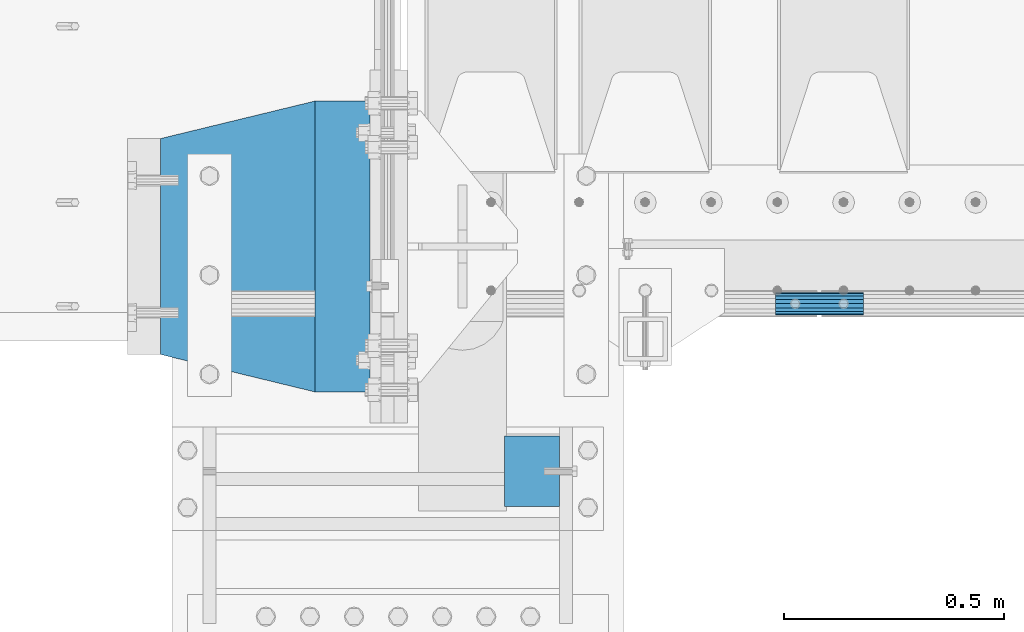
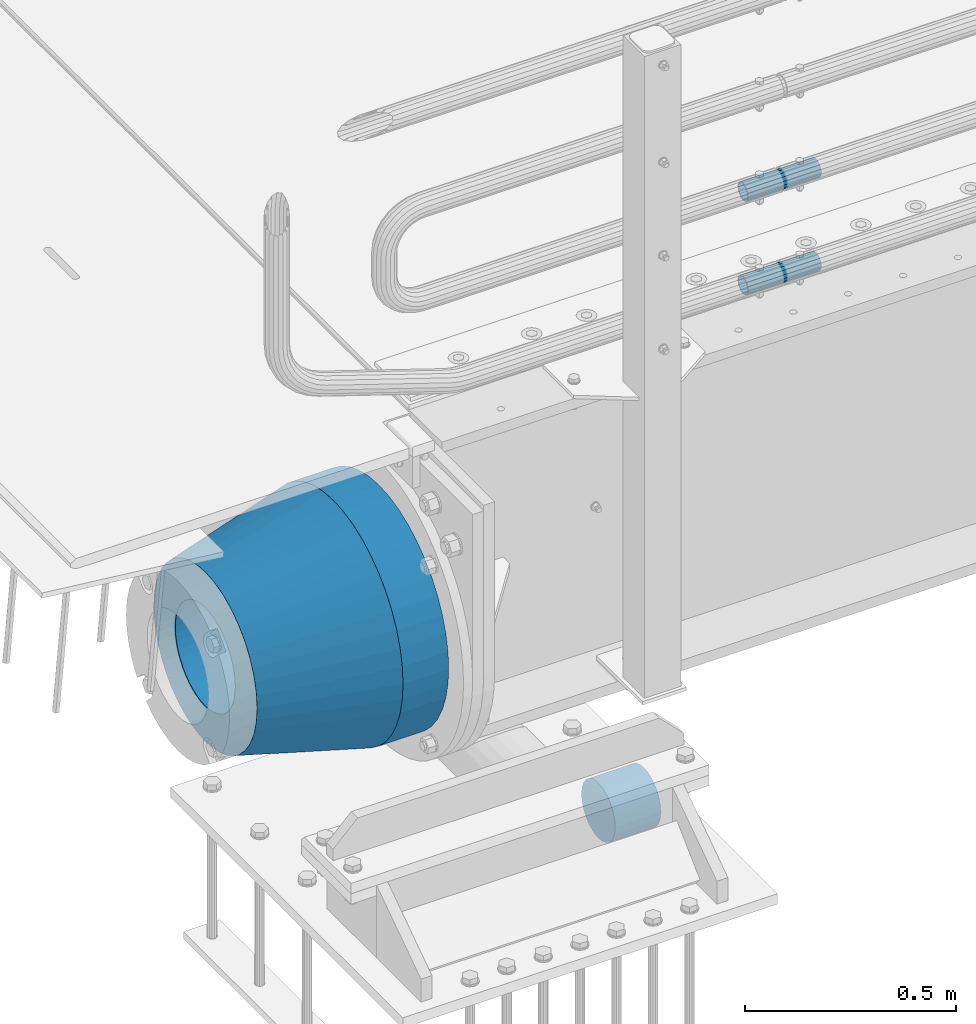
# One storey, part 121 of 219: 5 beams.
"""IFC2X3 building model written with IfcOpenShell, lengths in millimetres."""

import ifcopenshell
import ifcopenshell.guid

model = None  # the IFC model being written
_history = None  # IfcOwnerHistory: only IFC2X3 demands one
_inside = {}  # id of a spatial element -> (the spatial element, [elements in it])
_under = {}  # id of a project, library or spatial element -> (it, [spatial elements below it])
_declared = {}  # id of a project -> (the project, [libraries it declares])
_typed = {}  # id of a type object -> (the type object, [elements of that type])
_made_of = {}  # id of a material, layer set ... -> (it, [elements and type objects made of it])


def new_model(schema):
    """Start an empty IFC model of exactly this schema.

    Asked for "IFC4X3", IfcOpenShell would pick the latest addendum, in which some entities
    have other attributes; the version numbers below select the first issue.
    IFC2X3 requires an IfcOwnerHistory on every rooted entity: one is made here for all.
    """
    global model, _history
    if schema == "IFC4X3":
        model = ifcopenshell.file(schema_version=(4, 3, 0, 0))
    else:
        model = ifcopenshell.file(schema=schema)
    _inside.clear()
    _under.clear()
    _declared.clear()
    _typed.clear()
    _made_of.clear()
    _history = None
    if model.schema == "IFC2X3":
        org = make("IfcOrganization", Name="unknown")
        user = make(
            "IfcPersonAndOrganization",
            ThePerson=make("IfcPerson", FamilyName="unknown"),
            TheOrganization=org,
        )
        app = make(
            "IfcApplication",
            ApplicationDeveloper=org,
            Version="unknown",
            ApplicationFullName="unknown",
            ApplicationIdentifier="unknown",
        )
        _history = make(
            "IfcOwnerHistory",
            OwningUser=user,
            OwningApplication=app,
            ChangeAction="ADDED",
            CreationDate=0,
        )
    return model


def make(cls, **values):
    """One entity of the class cls with the attributes given. An attribute that is None is left unset."""
    return model.create_entity(
        cls, **{name: value for name, value in values.items() if value is not None}
    )


def rooted(cls, **values):
    """An entity with a GlobalId (a new one), such as an element, a storey or a relation."""
    return make(cls, GlobalId=ifcopenshell.guid.new(), OwnerHistory=_history, **values)


def si_unit(unit_type, name, prefix=None):
    """IfcSIUnit, for example si_unit("LENGTHUNIT", "METRE", prefix="MILLI")."""
    return make("IfcSIUnit", UnitType=unit_type, Prefix=prefix, Name=name)


def assignment(units):
    """IfcUnitAssignment: the units of a project."""
    return None if units is None else make("IfcUnitAssignment", Units=units)


def point(xyz):
    """IfcCartesianPoint."""
    return None if xyz is None else make("IfcCartesianPoint", Coordinates=xyz)


def direction(xyz):
    """IfcDirection."""
    return None if xyz is None else make("IfcDirection", DirectionRatios=xyz)


def frame(location, z_axis=None, x_axis=None):
    """IfcAxis2Placement3D, a coordinate frame: its origin and axes. An axis left out is left unset."""
    return make(
        "IfcAxis2Placement3D",
        Location=point(location),
        Axis=direction(z_axis),
        RefDirection=direction(x_axis),
    )


def origin_with_axes():
    """The frame at (0, 0, 0) with the z axis (0, 0, 1) and the x axis (1, 0, 0) written out."""
    return frame((0.0, 0.0, 0.0), z_axis=(0.0, 0.0, 1.0), x_axis=(1.0, 0.0, 0.0))


def place(relative_to, where):
    """IfcLocalPlacement: puts the frame where relative to a parent placement (None: the world)."""
    return make(
        "IfcLocalPlacement", PlacementRelTo=relative_to, RelativePlacement=where
    )


def context(
    kind, dimensions, precision=None, world=None, true_north=None, identifier=None
):
    """IfcGeometricRepresentationContext, for example the 3D "Model" context."""
    return make(
        "IfcGeometricRepresentationContext",
        ContextIdentifier=identifier,
        ContextType=kind,
        CoordinateSpaceDimension=dimensions,
        Precision=precision,
        WorldCoordinateSystem=world,
        TrueNorth=true_north,
    )


def subcontext(parent, identifier, kind, view, scale=None):
    """IfcGeometricRepresentationSubContext, for example "Body" below "Model"."""
    return make(
        "IfcGeometricRepresentationSubContext",
        ContextIdentifier=identifier,
        ContextType=kind,
        ParentContext=parent,
        TargetScale=scale,
        TargetView=view,
    )


def project(units=None, contexts=None):
    """IfcProject with its units and contexts."""
    return rooted(
        "IfcProject",
        Name="project",
        RepresentationContexts=contexts,
        UnitsInContext=assignment(units),
    )


def spatial(cls, under=None, at=None, **own):
    """A site, building, storey or space (cls), placed at a placement, below another one or the project."""
    s = rooted(cls, ObjectPlacement=at, **own)
    if under is not None:
        _under.setdefault(under.id(), (under, []))[1].append(s)
    return s


def faces_of(points, faces, orient=None, outer=None):
    """IfcFace entities. A face is a list of loops; a loop is a list of indices into points, from 0.

    orient and outer hold one flag for each loop. By default every Orientation is true, the
    first loop of a face is its IfcFaceOuterBound and the others are IfcFaceBound.
    """
    made = []
    for i, loops in enumerate(faces):
        bounds = []
        for j, loop in enumerate(loops):
            is_outer = j == 0 if outer is None else outer[i][j]
            bounds.append(
                make(
                    "IfcFaceOuterBound" if is_outer else "IfcFaceBound",
                    Bound=make("IfcPolyLoop", Polygon=[points[k] for k in loop]),
                    Orientation=True if orient is None else orient[i][j],
                )
            )
        made.append(make("IfcFace", Bounds=bounds))
    return made


def faceted_brep(points, faces, orient=None, outer=None, voids=None):
    """IfcFacetedBrep: a solid bounded by flat faces; with voids (closed shells), ...WithVoids."""
    shared = [point(p) for p in points]
    hull = make("IfcClosedShell", CfsFaces=faces_of(shared, faces, orient, outer))
    if voids is None:
        return make("IfcFacetedBrep", Outer=hull)
    return make(
        "IfcFacetedBrepWithVoids",
        Outer=hull,
        Voids=[
            make(cls, CfsFaces=faces_of(shared, fs, o, b)) for cls, fs, o, b in voids
        ],
    )


def shape(context_of_items, identifier, shape_type, items):
    """IfcShapeRepresentation: the items that make up one representation, for example the "Body"."""
    return make(
        "IfcShapeRepresentation",
        ContextOfItems=context_of_items,
        RepresentationIdentifier=identifier,
        RepresentationType=shape_type,
        Items=items,
    )


def material(Name=None, Category=None):
    """IfcMaterial."""
    return make("IfcMaterial", Name=Name, Category=Category)


def made_of(thing, what):
    """Note that an element or type object is made of a material, layer set ...; save() writes the relation."""
    if what is not None:
        _made_of.setdefault(what.id(), (what, []))[1].append(thing)
    return thing


def type_object(cls, material=None, **own):
    """A type object (cls), such as IfcWallType, which elements share."""
    return made_of(rooted(cls, **own), material)


def element(
    cls,
    number,
    at=None,
    inside=None,
    cuts=None,
    type_object=None,
    material=None,
    context=None,
    identifier="Body",
    shape_type=None,
    held_by="IfcProductDefinitionShape",
    body=None,
    shapes=None,
    **own,
):
    """One element of the class cls, such as IfcWall. Its Tag is "e" and its number.

    at: its placement. inside: the storey or other place that contains it. cuts: it is an
    opening in that element (IfcRelVoidsElement). A single representation is given by context,
    identifier, shape_type and body (its items); several are given by shapes. held_by: the class
    of the entity that holds the representations. save() writes the other relations.
    """
    e = rooted(cls, Tag="e%d" % number, ObjectPlacement=at, **own)
    if body is not None:
        shapes = [shape(context, identifier, shape_type, body)]
    if shapes is not None:
        e.Representation = make(held_by, Representations=shapes)
    if inside is not None:
        _inside.setdefault(inside.id(), (inside, []))[1].append(e)
    if cuts is not None:
        rooted(
            "IfcRelVoidsElement", RelatingBuildingElement=cuts, RelatedOpeningElement=e
        )
    if type_object is not None:
        _typed.setdefault(type_object.id(), (type_object, []))[1].append(e)
    return made_of(e, material)


def aggregate(whole, parts):
    """IfcRelAggregates: a whole, such as a stair, and the parts it consists of."""
    return rooted("IfcRelAggregates", RelatingObject=whole, RelatedObjects=parts)


def save(model, path):
    """Write the relations noted so far, then the file.

    IfcRelAggregates (storeys below a building ...), IfcRelContainedInSpatialStructure (elements
    in a storey), IfcRelDefinesByType, IfcRelAssociatesMaterial and IfcRelDeclares: one each for
    every whole, place, type object, material and project.
    """
    for whole, parts in _under.values():
        aggregate(whole, parts)
    for where, things in _inside.values():
        rooted(
            "IfcRelContainedInSpatialStructure",
            RelatedElements=things,
            RelatingStructure=where,
        )
    for kind, things in _typed.values():
        rooted("IfcRelDefinesByType", RelatedObjects=things, RelatingType=kind)
    for what, things in _made_of.values():
        rooted("IfcRelAssociatesMaterial", RelatedObjects=things, RelatingMaterial=what)
    for by, libraries in _declared.values():
        rooted("IfcRelDeclares", RelatingContext=by, RelatedDefinitions=libraries)
    model.write(path)


model = new_model("IFC2X3")

# Units and contexts
model_context = context("Model", 3, precision=1e-05, world=origin_with_axes())
body_context = subcontext(model_context, "Body", "Model", "MODEL_VIEW")
ifc_project = project(units=[si_unit("LENGTHUNIT", "METRE", prefix="MILLI"), si_unit("AREAUNIT", "SQUARE_METRE"), si_unit("VOLUMEUNIT", "CUBIC_METRE"), si_unit("MASSUNIT", "GRAM", prefix="KILO"), si_unit("TIMEUNIT", "SECOND"), si_unit("PLANEANGLEUNIT", "RADIAN"), si_unit("SOLIDANGLEUNIT", "STERADIAN"), si_unit("THERMODYNAMICTEMPERATUREUNIT", "DEGREE_CELSIUS"), si_unit("LUMINOUSINTENSITYUNIT", "LUMEN")], contexts=[model_context])

# Site, building, storey
site_placement = place(None, origin_with_axes())
site = spatial("IfcSite", under=ifc_project, at=site_placement, CompositionType="ELEMENT")
building_placement = place(site_placement, origin_with_axes())
building = spatial("IfcBuilding", under=site, at=building_placement, Name="Standard", CompositionType="ELEMENT")
storey_placement = place(building_placement, origin_with_axes())
storey = spatial("IfcBuildingStorey", under=building, at=storey_placement, Name="Undefined", CompositionType="ELEMENT", Elevation=0.0)

# Beams
ifc_material_1 = material()
beam_type_1 = type_object("IfcBeamType", PredefinedType="NOTDEFINED")
beam_1_placement = place(storey_placement, frame((230.000000000011, 23490.000000001, -923.000000000004), z_axis=(0.0, 0.0, -1.0), x_axis=(1.0, 0.0, 0.0)))
element("IfcBeam", 1, at=beam_1_placement, inside=storey, type_object=beam_type_1, material=ifc_material_1, context=body_context, shape_type="Brep", body=[
    faceted_brep([(0.0, -80.0, 0.0), (0.0, -77.2740661031239, -20.7055236082017), (125.0, -77.2740661031239, -20.7055236082017), (125.0, -80.0, 0.0), (0.0, -69.2820323027554, -40.0), (125.0, -69.2820323027554, -40.0), (0.0, -56.5685424949224, -56.5685424949238), (125.0, -56.5685424949224, -56.5685424949238), (0.0, -40.0, -69.2820323027552), (125.0, -40.0, -69.2820323027552), (0.0, -20.7055236082015, -77.2740661031255), (125.0, -20.7055236082015, -77.2740661031255), (0.0, 0.0, -80.0), (125.0, 0.0, -80.0), (0.0, 20.7055236082015, -77.2740661031255), (125.0, 20.7055236082015, -77.2740661031255), (0.0, 40.0, -69.2820323027551), (125.0, 40.0, -69.2820323027551), (0.0, 56.5685424949224, -56.5685424949238), (125.0, 56.5685424949224, -56.5685424949238), (0.0, 69.2820323027554, -40.0), (125.0, 69.2820323027554, -40.0), (0.0, 77.2740661031239, -20.7055236082016), (125.0, 77.2740661031239, -20.7055236082016), (0.0, 80.0, 0.0), (125.0, 80.0, 0.0), (0.0, 77.2740661031239, 20.7055236082017), (125.0, 77.2740661031239, 20.7055236082017), (0.0, 69.2820323027554, 40.0), (125.0, 69.2820323027554, 40.0), (0.0, 56.5685424949224, 56.5685424949238), (125.0, 56.5685424949224, 56.5685424949238), (0.0, 40.0, 69.2820323027551), (125.0, 40.0, 69.2820323027551), (0.0, 20.7055236082015, 77.2740661031255), (125.0, 20.7055236082015, 77.2740661031255), (0.0, 0.0, 80.0), (125.0, 0.0, 80.0), (0.0, -20.7055236082015, 77.2740661031255), (125.0, -20.7055236082015, 77.2740661031255), (0.0, -40.0, 69.2820323027551), (125.0, -40.0, 69.2820323027551), (0.0, -56.5685424949224, 56.5685424949238), (125.0, -56.5685424949224, 56.5685424949238), (0.0, -69.2820323027554, 40.0), (125.0, -69.2820323027554, 40.0), (0.0, -77.2740661031239, 20.7055236082017), (125.0, -77.2740661031239, 20.7055236082017)], [[[0, 1, 2, 3]], [[1, 4, 5, 2]], [[4, 6, 7, 5]], [[6, 8, 9, 7]], [[8, 10, 11, 9]], [[10, 12, 13, 11]], [[12, 14, 15, 13]], [[14, 16, 17, 15]], [[16, 18, 19, 17]], [[18, 20, 21, 19]], [[20, 22, 23, 21]], [[22, 24, 25, 23]], [[24, 26, 27, 25]], [[26, 28, 29, 27]], [[28, 30, 31, 29]], [[30, 32, 33, 31]], [[32, 34, 35, 33]], [[34, 36, 37, 35]], [[36, 38, 39, 37]], [[38, 40, 41, 39]], [[40, 42, 43, 41]], [[42, 44, 45, 43]], [[44, 46, 47, 45]], [[46, 0, 3, 47]], [[5, 7, 9, 11, 13, 15, 17, 19, 21, 23, 25, 27, 29, 31, 33, 35, 37, 39, 41, 43, 45, 47, 3, 2]], [[46, 44, 42, 40, 38, 36, 34, 32, 30, 28, 26, 24, 22, 20, 18, 16, 14, 12, 10, 8, 6, 4, 1, 0]]]),
])
ifc_material_2 = material()
beam_type_2 = type_object("IfcBeamType", PredefinedType="NOTDEFINED")
beam_2_placement = place(storey_placement, frame((844.997502999948, 23870.1500000004, 149.849999999747), z_axis=(0.0, 0.0, 1.0), x_axis=(1.0, 0.0, 0.0)))
element("IfcBeam", 2, at=beam_2_placement, inside=storey, type_object=beam_type_2, material=ifc_material_2, context=body_context, shape_type="Brep", body=[
    faceted_brep([(0.0, -21.9000000000015, 0.0), (0.0, -20.232961761998, 8.38076716879547), (200.0, -20.232961761998, 8.38076716879547), (200.0, -21.9000000000015, 0.0), (0.0, -15.4856385079838, 15.4856385079854), (200.0, -15.4856385079838, 15.4856385079854), (0.0, -8.38076716879732, 20.2329617619972), (200.0, -8.38076716879732, 20.2329617619972), (0.0, 0.0, 21.9), (200.0, 0.0, 21.9), (0.0, 8.38076716879732, 20.2329617619972), (200.0, 8.38076716879732, 20.2329617619972), (0.0, 15.4856385079838, 15.4856385079854), (200.0, 15.4856385079838, 15.4856385079854), (0.0, 20.232961761998, 8.38076716879547), (200.0, 20.232961761998, 8.38076716879547), (0.0, 21.9000000000015, 0.0), (200.0, 21.9000000000015, 0.0), (0.0, 20.232961761998, -8.38076716879547), (200.0, 20.232961761998, -8.38076716879547), (0.0, 15.4856385079838, -15.4856385079854), (200.0, 15.4856385079838, -15.4856385079854), (0.0, 8.38076716879732, -20.2329617619972), (200.0, 8.38076716879732, -20.2329617619972), (0.0, 0.0, -21.9), (200.0, 0.0, -21.9), (0.0, -8.38076716879732, -20.2329617619972), (200.0, -8.38076716879732, -20.2329617619972), (0.0, -15.4856385079838, -15.4856385079854), (200.0, -15.4856385079838, -15.4856385079854), (0.0, -20.232961761998, -8.38076716879547), (200.0, -20.232961761998, -8.38076716879547), (0.0, -25.5, 0.0), (0.0, -23.5589280790373, -9.7584275253098), (200.0, -23.5589280790373, -9.7584275253098), (200.0, -25.5, 0.0), (0.0, -18.0312229202536, -18.031222920257), (200.0, -18.0312229202536, -18.031222920257), (0.0, -9.75842752531025, -23.5589280790378), (200.0, -9.75842752531025, -23.5589280790378), (0.0, 0.0, -25.5), (200.0, 0.0, -25.5), (0.0, 9.75842752531025, -23.5589280790378), (200.0, 9.75842752531025, -23.5589280790378), (0.0, 18.0312229202536, -18.031222920257), (200.0, 18.0312229202536, -18.031222920257), (0.0, 23.5589280790373, -9.7584275253098), (200.0, 23.5589280790373, -9.7584275253098), (0.0, 25.5, 0.0), (200.0, 25.5, 0.0), (0.0, 23.5589280790373, 9.7584275253098), (200.0, 23.5589280790373, 9.7584275253098), (0.0, 18.0312229202536, 18.031222920257), (200.0, 18.0312229202536, 18.031222920257), (0.0, 9.75842752531025, 23.5589280790378), (200.0, 9.75842752531025, 23.5589280790378), (0.0, 0.0, 25.5), (200.0, 0.0, 25.5), (0.0, -9.75842752531025, 23.5589280790378), (200.0, -9.75842752531025, 23.5589280790378), (0.0, -18.0312229202536, 18.031222920257), (200.0, -18.0312229202536, 18.031222920257), (0.0, -23.5589280790373, 9.7584275253098), (200.0, -23.5589280790373, 9.7584275253098)], [[[0, 1, 2, 3]], [[1, 4, 5, 2]], [[4, 6, 7, 5]], [[6, 8, 9, 7]], [[8, 10, 11, 9]], [[10, 12, 13, 11]], [[12, 14, 15, 13]], [[14, 16, 17, 15]], [[16, 18, 19, 17]], [[18, 20, 21, 19]], [[20, 22, 23, 21]], [[22, 24, 25, 23]], [[24, 26, 27, 25]], [[26, 28, 29, 27]], [[28, 30, 31, 29]], [[30, 0, 3, 31]], [[32, 33, 34, 35]], [[33, 36, 37, 34]], [[36, 38, 39, 37]], [[38, 40, 41, 39]], [[40, 42, 43, 41]], [[42, 44, 45, 43]], [[44, 46, 47, 45]], [[46, 48, 49, 47]], [[48, 50, 51, 49]], [[50, 52, 53, 51]], [[52, 54, 55, 53]], [[54, 56, 57, 55]], [[56, 58, 59, 57]], [[58, 60, 61, 59]], [[60, 62, 63, 61]], [[62, 32, 35, 63]], [[37, 39, 41, 43, 45, 47, 49, 51, 53, 55, 57, 59, 61, 63, 35, 34], [5, 7, 9, 11, 13, 15, 17, 19, 21, 23, 25, 27, 29, 31, 3, 2]], [[62, 60, 58, 56, 54, 52, 50, 48, 46, 44, 42, 40, 38, 36, 33, 32], [30, 28, 26, 24, 22, 20, 18, 16, 14, 12, 10, 8, 6, 4, 1, 0]]]),
])
beam_3_placement = place(storey_placement, frame((844.997502999948, 23870.1500000004, 420.149999999747), z_axis=(0.0, 0.0, 1.0), x_axis=(1.0, 0.0, 0.0)))
element("IfcBeam", 3, at=beam_3_placement, inside=storey, type_object=beam_type_2, material=ifc_material_2, context=body_context, shape_type="Brep", body=[
    faceted_brep([(0.0, -21.9000000000015, 0.0), (0.0, -20.232961761998, 8.38076716879547), (200.0, -20.232961761998, 8.38076716879547), (200.0, -21.9000000000015, 0.0), (0.0, -15.4856385079838, 15.4856385079854), (200.0, -15.4856385079838, 15.4856385079854), (0.0, -8.38076716879732, 20.2329617619972), (200.0, -8.38076716879732, 20.2329617619972), (0.0, 0.0, 21.9), (200.0, 0.0, 21.9), (0.0, 8.38076716879732, 20.2329617619972), (200.0, 8.38076716879732, 20.2329617619972), (0.0, 15.4856385079838, 15.4856385079854), (200.0, 15.4856385079838, 15.4856385079854), (0.0, 20.232961761998, 8.38076716879547), (200.0, 20.232961761998, 8.38076716879547), (0.0, 21.9000000000015, 0.0), (200.0, 21.9000000000015, 0.0), (0.0, 20.232961761998, -8.38076716879547), (200.0, 20.232961761998, -8.38076716879547), (0.0, 15.4856385079838, -15.4856385079854), (200.0, 15.4856385079838, -15.4856385079854), (0.0, 8.38076716879732, -20.2329617619972), (200.0, 8.38076716879732, -20.2329617619972), (0.0, 0.0, -21.9), (200.0, 0.0, -21.9), (0.0, -8.38076716879732, -20.2329617619972), (200.0, -8.38076716879732, -20.2329617619972), (0.0, -15.4856385079838, -15.4856385079854), (200.0, -15.4856385079838, -15.4856385079854), (0.0, -20.232961761998, -8.38076716879547), (200.0, -20.232961761998, -8.38076716879547), (0.0, -25.5, 0.0), (0.0, -23.5589280790373, -9.7584275253098), (200.0, -23.5589280790373, -9.7584275253098), (200.0, -25.5, 0.0), (0.0, -18.0312229202536, -18.031222920257), (200.0, -18.0312229202536, -18.031222920257), (0.0, -9.75842752531025, -23.5589280790378), (200.0, -9.75842752531025, -23.5589280790378), (0.0, 0.0, -25.5), (200.0, 0.0, -25.5), (0.0, 9.75842752531025, -23.5589280790378), (200.0, 9.75842752531025, -23.5589280790378), (0.0, 18.0312229202536, -18.031222920257), (200.0, 18.0312229202536, -18.031222920257), (0.0, 23.5589280790373, -9.7584275253098), (200.0, 23.5589280790373, -9.7584275253098), (0.0, 25.5, 0.0), (200.0, 25.5, 0.0), (0.0, 23.5589280790373, 9.7584275253098), (200.0, 23.5589280790373, 9.7584275253098), (0.0, 18.0312229202536, 18.031222920257), (200.0, 18.0312229202536, 18.031222920257), (0.0, 9.75842752531025, 23.5589280790378), (200.0, 9.75842752531025, 23.5589280790378), (0.0, 0.0, 25.5), (200.0, 0.0, 25.5), (0.0, -9.75842752531025, 23.5589280790378), (200.0, -9.75842752531025, 23.5589280790378), (0.0, -18.0312229202536, 18.031222920257), (200.0, -18.0312229202536, 18.031222920257), (0.0, -23.5589280790373, 9.7584275253098), (200.0, -23.5589280790373, 9.7584275253098)], [[[0, 1, 2, 3]], [[1, 4, 5, 2]], [[4, 6, 7, 5]], [[6, 8, 9, 7]], [[8, 10, 11, 9]], [[10, 12, 13, 11]], [[12, 14, 15, 13]], [[14, 16, 17, 15]], [[16, 18, 19, 17]], [[18, 20, 21, 19]], [[20, 22, 23, 21]], [[22, 24, 25, 23]], [[24, 26, 27, 25]], [[26, 28, 29, 27]], [[28, 30, 31, 29]], [[30, 0, 3, 31]], [[32, 33, 34, 35]], [[33, 36, 37, 34]], [[36, 38, 39, 37]], [[38, 40, 41, 39]], [[40, 42, 43, 41]], [[42, 44, 45, 43]], [[44, 46, 47, 45]], [[46, 48, 49, 47]], [[48, 50, 51, 49]], [[50, 52, 53, 51]], [[52, 54, 55, 53]], [[54, 56, 57, 55]], [[56, 58, 59, 57]], [[58, 60, 61, 59]], [[60, 62, 63, 61]], [[62, 32, 35, 63]], [[37, 39, 41, 43, 45, 47, 49, 51, 53, 55, 57, 59, 61, 63, 35, 34], [5, 7, 9, 11, 13, 15, 17, 19, 21, 23, 25, 27, 29, 31, 3, 2]], [[62, 60, 58, 56, 54, 52, 50, 48, 46, 44, 42, 40, 38, 36, 33, 32], [30, 28, 26, 24, 22, 20, 18, 16, 14, 12, 10, 8, 6, 4, 1, 0]]]),
])
ifc_material_3 = material(Name="STEEL/S355N")
beam_type_3 = type_object("IfcBeamType", PredefinedType="NOTDEFINED")
beam_4_placement = place(storey_placement, frame((-74.999999999991, 24000.0, -515.0), z_axis=(0.0, 0.0, 1.0), x_axis=(-1.0, 0.0, 0.0)))
element("IfcBeam", 4, at=beam_4_placement, inside=storey, type_object=beam_type_3, material=ifc_material_3, context=body_context, shape_type="Brep", body=[
    faceted_brep([(0.0, -215.0, 0.0), (0.0, -212.811610004399, 30.5976902287563), (125.0, -212.811610004399, 30.5976902287563), (125.0, -215.0, 0.0), (0.0, -206.290989327113, 60.5724997209074), (125.0, -206.290989327113, 60.5724997209074), (0.0, -195.570879001221, 89.3142277954056), (125.0, -195.570879001221, 89.3142277954056), (0.0, -180.869509558703, 116.237775752953), (125.0, -180.869509558703, 116.237775752953), (0.0, -162.486158486165, 140.795057798236), (125.0, -162.486158486165, 140.795057798236), (0.0, -140.795057798234, 162.486158486165), (125.0, -140.795057798234, 162.486158486165), (0.0, -116.237775752954, 180.869509558704), (125.0, -116.237775752954, 180.869509558704), (0.0, -89.314227795403, 195.570879001222), (125.0, -89.314227795403, 195.570879001222), (0.0, -60.5724997209109, 206.290989327117), (125.0, -60.5724997209109, 206.290989327117), (0.0, -30.5976902287584, 212.811610004401), (125.0, -30.5976902287584, 212.811610004401), (0.0, 0.0, 215.0), (125.0, 0.0, 215.0), (0.0, 30.5976902287584, 212.811610004401), (125.0, 30.5976902287584, 212.811610004401), (0.0, 60.5724997209109, 206.290989327117), (125.0, 60.5724997209109, 206.290989327117), (0.0, 89.314227795403, 195.570879001221), (125.0, 89.314227795403, 195.570879001221), (0.0, 116.237775752954, 180.869509558704), (125.0, 116.237775752954, 180.869509558704), (0.0, 140.795057798234, 162.486158486165), (125.0, 140.795057798234, 162.486158486165), (0.0, 162.486158486165, 140.795057798236), (125.0, 162.486158486165, 140.795057798236), (0.0, 180.869509558703, 116.237775752953), (125.0, 180.869509558703, 116.237775752953), (0.0, 195.570879001221, 89.3142277954056), (125.0, 195.570879001221, 89.3142277954056), (0.0, 206.290989327113, 60.5724997209073), (125.0, 206.290989327113, 60.5724997209073), (0.0, 212.811610004399, 30.5976902287563), (125.0, 212.811610004399, 30.5976902287563), (0.0, 215.0, 0.0), (125.0, 215.0, 0.0), (0.0, 212.811610004399, -30.5976902287563), (125.0, 212.811610004399, -30.5976902287563), (0.0, 206.290989327113, -60.5724997209073), (125.0, 206.290989327113, -60.5724997209073), (0.0, 195.570879001221, -89.3142277954056), (125.0, 195.570879001221, -89.3142277954056), (0.0, 180.869509558703, -116.237775752954), (125.0, 180.869509558703, -116.237775752954), (0.0, 162.486158486165, -140.795057798236), (125.0, 162.486158486165, -140.795057798236), (0.0, 140.795057798234, -162.486158486166), (125.0, 140.795057798234, -162.486158486166), (0.0, 116.237775752954, -180.869509558704), (125.0, 116.237775752954, -180.869509558704), (0.0, 89.314227795403, -195.570879001221), (125.0, 89.314227795403, -195.570879001221), (0.0, 60.5724997209109, -206.290989327117), (125.0, 60.5724997209109, -206.290989327117), (0.0, 30.5976902287584, -212.811610004401), (125.0, 30.5976902287584, -212.811610004401), (0.0, 0.0, -215.0), (125.0, 0.0, -215.0), (0.0, -30.5976902287584, -212.811610004401), (125.0, -30.5976902287584, -212.811610004401), (0.0, -60.5724997209109, -206.290989327117), (125.0, -60.5724997209109, -206.290989327117), (0.0, -89.314227795403, -195.570879001221), (125.0, -89.314227795403, -195.570879001221), (0.0, -116.237775752954, -180.869509558704), (125.0, -116.237775752954, -180.869509558704), (0.0, -140.795057798234, -162.486158486166), (125.0, -140.795057798234, -162.486158486166), (0.0, -162.486158486165, -140.795057798236), (125.0, -162.486158486165, -140.795057798236), (0.0, -180.869509558703, -116.237775752953), (125.0, -180.869509558703, -116.237775752953), (0.0, -195.570879001221, -89.3142277954056), (125.0, -195.570879001221, -89.3142277954056), (0.0, -206.290989327113, -60.5724997209073), (125.0, -206.290989327113, -60.5724997209073), (0.0, -212.811610004399, -30.5976902287563), (125.0, -212.811610004399, -30.5976902287563), (0.0, -330.0, 0.0), (0.0, -326.641075820706, -46.9638966301842), (125.0, -326.641075820706, -46.9638966301842), (125.0, -330.0, 0.0), (0.0, -316.632681292787, -92.9717437576718), (125.0, -316.632681292787, -92.9717437576718), (0.0, -300.178558466992, -137.086954290623), (125.0, -300.178558466992, -137.086954290623), (0.0, -277.613665834288, -178.411469760347), (125.0, -277.613665834288, -178.411469760347), (0.0, -249.397359536903, -216.104042201944), (125.0, -249.397359536903, -216.104042201944), (0.0, -216.104042201943, -249.397359536905), (125.0, -216.104042201943, -249.397359536905), (0.0, -178.411469760344, -277.61366583429), (125.0, -178.411469760344, -277.61366583429), (0.0, -137.086954290622, -300.178558466991), (125.0, -137.086954290622, -300.178558466991), (0.0, -92.9717437576692, -316.632681292784), (125.0, -92.9717437576692, -316.632681292784), (0.0, -46.9638966301864, -326.641075820708), (125.0, -46.9638966301864, -326.641075820708), (0.0, 0.0, -330.0), (125.0, 0.0, -330.0), (0.0, 46.9638966301864, -326.641075820708), (125.0, 46.9638966301864, -326.641075820708), (0.0, 92.9717437576692, -316.632681292784), (125.0, 92.9717437576692, -316.632681292784), (0.0, 137.086954290622, -300.178558466991), (125.0, 137.086954290622, -300.178558466991), (0.0, 178.411469760344, -277.61366583429), (125.0, 178.411469760344, -277.61366583429), (0.0, 216.104042201943, -249.397359536905), (125.0, 216.104042201943, -249.397359536905), (0.0, 249.397359536906, -216.104042201944), (125.0, 249.397359536906, -216.104042201944), (0.0, 277.613665834291, -178.411469760347), (125.0, 277.613665834291, -178.411469760347), (0.0, 300.178558466992, -137.086954290623), (125.0, 300.178558466992, -137.086954290623), (0.0, 316.632681292784, -92.9717437576717), (125.0, 316.632681292784, -92.9717437576717), (0.0, 326.641075820709, -46.9638966301841), (125.0, 326.641075820709, -46.9638966301841), (0.0, 330.0, 0.0), (125.0, 330.0, 0.0), (0.0, 326.641075820709, 46.9638966301841), (125.0, 326.641075820709, 46.9638966301841), (0.0, 316.632681292784, 92.9717437576718), (125.0, 316.632681292784, 92.9717437576718), (0.0, 300.178558466992, 137.086954290622), (125.0, 300.178558466992, 137.086954290622), (0.0, 277.613665834291, 178.411469760347), (125.0, 277.613665834291, 178.411469760347), (0.0, 249.397359536906, 216.104042201944), (125.0, 249.397359536906, 216.104042201944), (0.0, 216.104042201943, 249.397359536905), (125.0, 216.104042201943, 249.397359536905), (0.0, 178.411469760344, 277.61366583429), (125.0, 178.411469760344, 277.61366583429), (0.0, 137.086954290622, 300.178558466991), (125.0, 137.086954290622, 300.178558466991), (0.0, 92.9717437576692, 316.632681292784), (125.0, 92.9717437576692, 316.632681292784), (0.0, 46.9638966301864, 326.641075820708), (125.0, 46.9638966301864, 326.641075820708), (0.0, 0.0, 330.0), (125.0, 0.0, 330.0), (0.0, -46.9638966301864, 326.641075820708), (125.0, -46.9638966301864, 326.641075820708), (0.0, -92.9717437576692, 316.632681292784), (125.0, -92.9717437576692, 316.632681292784), (0.0, -137.086954290622, 300.178558466991), (125.0, -137.086954290622, 300.178558466991), (0.0, -178.411469760344, 277.61366583429), (125.0, -178.411469760344, 277.61366583429), (0.0, -216.104042201943, 249.397359536905), (125.0, -216.104042201943, 249.397359536905), (0.0, -249.397359536903, 216.104042201944), (125.0, -249.397359536903, 216.104042201944), (0.0, -277.613665834288, 178.411469760347), (125.0, -277.613665834288, 178.411469760347), (0.0, -300.178558466992, 137.086954290623), (125.0, -300.178558466992, 137.086954290623), (0.0, -316.632681292787, 92.9717437576718), (125.0, -316.632681292787, 92.9717437576718), (0.0, -326.641075820706, 46.9638966301841), (125.0, -326.641075820706, 46.9638966301841)], [[[0, 1, 2, 3]], [[1, 4, 5, 2]], [[4, 6, 7, 5]], [[6, 8, 9, 7]], [[8, 10, 11, 9]], [[10, 12, 13, 11]], [[12, 14, 15, 13]], [[14, 16, 17, 15]], [[16, 18, 19, 17]], [[18, 20, 21, 19]], [[20, 22, 23, 21]], [[22, 24, 25, 23]], [[24, 26, 27, 25]], [[26, 28, 29, 27]], [[28, 30, 31, 29]], [[30, 32, 33, 31]], [[32, 34, 35, 33]], [[34, 36, 37, 35]], [[36, 38, 39, 37]], [[38, 40, 41, 39]], [[40, 42, 43, 41]], [[42, 44, 45, 43]], [[44, 46, 47, 45]], [[46, 48, 49, 47]], [[48, 50, 51, 49]], [[50, 52, 53, 51]], [[52, 54, 55, 53]], [[54, 56, 57, 55]], [[56, 58, 59, 57]], [[58, 60, 61, 59]], [[60, 62, 63, 61]], [[62, 64, 65, 63]], [[64, 66, 67, 65]], [[66, 68, 69, 67]], [[68, 70, 71, 69]], [[70, 72, 73, 71]], [[72, 74, 75, 73]], [[74, 76, 77, 75]], [[76, 78, 79, 77]], [[78, 80, 81, 79]], [[80, 82, 83, 81]], [[82, 84, 85, 83]], [[84, 86, 87, 85]], [[86, 0, 3, 87]], [[88, 89, 90, 91]], [[89, 92, 93, 90]], [[92, 94, 95, 93]], [[94, 96, 97, 95]], [[96, 98, 99, 97]], [[98, 100, 101, 99]], [[100, 102, 103, 101]], [[102, 104, 105, 103]], [[104, 106, 107, 105]], [[106, 108, 109, 107]], [[108, 110, 111, 109]], [[110, 112, 113, 111]], [[112, 114, 115, 113]], [[114, 116, 117, 115]], [[116, 118, 119, 117]], [[118, 120, 121, 119]], [[120, 122, 123, 121]], [[122, 124, 125, 123]], [[124, 126, 127, 125]], [[126, 128, 129, 127]], [[128, 130, 131, 129]], [[130, 132, 133, 131]], [[132, 134, 135, 133]], [[134, 136, 137, 135]], [[136, 138, 139, 137]], [[138, 140, 141, 139]], [[140, 142, 143, 141]], [[142, 144, 145, 143]], [[144, 146, 147, 145]], [[146, 148, 149, 147]], [[148, 150, 151, 149]], [[150, 152, 153, 151]], [[152, 154, 155, 153]], [[154, 156, 157, 155]], [[156, 158, 159, 157]], [[158, 160, 161, 159]], [[160, 162, 163, 161]], [[162, 164, 165, 163]], [[164, 166, 167, 165]], [[166, 168, 169, 167]], [[168, 170, 171, 169]], [[170, 172, 173, 171]], [[172, 174, 175, 173]], [[174, 88, 91, 175]], [[93, 95, 97, 99, 101, 103, 105, 107, 109, 111, 113, 115, 117, 119, 121, 123, 125, 127, 129, 131, 133, 135, 137, 139, 141, 143, 145, 147, 149, 151, 153, 155, 157, 159, 161, 163, 165, 167, 169, 171, 173, 175, 91, 90], [5, 7, 9, 11, 13, 15, 17, 19, 21, 23, 25, 27, 29, 31, 33, 35, 37, 39, 41, 43, 45, 47, 49, 51, 53, 55, 57, 59, 61, 63, 65, 67, 69, 71, 73, 75, 77, 79, 81, 83, 85, 87, 3, 2]], [[174, 172, 170, 168, 166, 164, 162, 160, 158, 156, 154, 152, 150, 148, 146, 144, 142, 140, 138, 136, 134, 132, 130, 128, 126, 124, 122, 120, 118, 116, 114, 112, 110, 108, 106, 104, 102, 100, 98, 96, 94, 92, 89, 88], [86, 84, 82, 80, 78, 76, 74, 72, 70, 68, 66, 64, 62, 60, 58, 56, 54, 52, 50, 48, 46, 44, 42, 40, 38, 36, 34, 32, 30, 28, 26, 24, 22, 20, 18, 16, 14, 12, 10, 8, 6, 4, 1, 0]]]),
])
ifc_material_4 = material(Name="SCN-500-E2")
beam_type_4 = type_object("IfcBeamType", PredefinedType="NOTDEFINED")
beam_5_placement = place(storey_placement, frame((-199.999999999991, 24000.0, -515.0), z_axis=(0.0, 0.0, 1.0), x_axis=(-1.0, 0.0, 0.0)))
element("IfcBeam", 5, at=beam_5_placement, inside=storey, type_object=beam_type_4, material=ifc_material_4, context=body_context, shape_type="Brep", body=[
    faceted_brep([(0.0, -330.0, 0.0), (0.0, -326.641075820706, -46.9638966301842), (350.0, -242.506253260828, -34.8671353769549), (350.0, -245.0, 0.0), (0.0, -316.632681292787, -92.9717437576718), (350.0, -235.075778535553, -69.0244764261503), (0.0, -300.178558466992, -137.086954290623), (350.0, -222.859838861856, -101.776678185462), (0.0, -277.613665834288, -178.411469760347), (350.0, -206.107115543637, -132.457000276621), (0.0, -249.397359536903, -216.104042201944), (350.0, -185.158645716794, -160.440879816595), (0.0, -216.104042201943, -249.397359536905), (350.0, -160.440879816597, -185.158645716793), (0.0, -178.411469760344, -277.61366583429), (350.0, -132.45700027662, -206.107115543639), (0.0, -137.086954290622, -300.178558466991), (350.0, -101.776678185459, -222.859838861857), (0.0, -92.9717437576692, -316.632681292784), (350.0, -69.0244764261515, -235.075778535552), (0.0, -46.9638966301864, -326.641075820708), (350.0, -34.8671353769532, -242.506253260829), (0.0, 0.0, -330.0), (350.0, 0.0, -245.0), (0.0, 46.9638966301864, -326.641075820708), (350.0, 34.8671353769532, -242.506253260829), (0.0, 92.9717437576692, -316.632681292784), (350.0, 69.0244764261515, -235.075778535552), (0.0, 137.086954290622, -300.178558466991), (350.0, 101.776678185459, -222.859838861857), (0.0, 178.411469760344, -277.61366583429), (350.0, 132.45700027662, -206.107115543639), (0.0, 216.104042201943, -249.397359536905), (350.0, 160.440879816597, -185.158645716793), (0.0, 249.397359536906, -216.104042201944), (350.0, 185.158645716794, -160.440879816595), (0.0, 277.613665834291, -178.411469760347), (350.0, 206.107115543637, -132.457000276621), (0.0, 300.178558466992, -137.086954290623), (350.0, 222.859838861856, -101.776678185462), (0.0, 316.632681292784, -92.9717437576717), (350.0, 235.075778535553, -69.0244764261502), (0.0, 326.641075820709, -46.9638966301841), (350.0, 242.506253260828, -34.8671353769548), (0.0, 330.0, 0.0), (350.0, 245.0, 0.0), (0.0, 326.641075820709, 46.9638966301841), (350.0, 242.506253260828, 34.8671353769549), (0.0, 316.632681292784, 92.9717437576718), (350.0, 235.075778535553, 69.0244764261503), (0.0, 300.178558466992, 137.086954290622), (350.0, 222.859838861856, 101.776678185462), (0.0, 277.613665834291, 178.411469760347), (350.0, 206.107115543637, 132.457000276621), (0.0, 249.397359536906, 216.104042201944), (350.0, 185.158645716794, 160.440879816595), (0.0, 216.104042201943, 249.397359536905), (350.0, 160.440879816597, 185.158645716793), (0.0, 178.411469760344, 277.61366583429), (350.0, 132.45700027662, 206.107115543639), (0.0, 137.086954290622, 300.178558466991), (350.0, 101.776678185459, 222.859838861857), (0.0, 92.9717437576692, 316.632681292784), (350.0, 69.0244764261515, 235.075778535552), (0.0, 46.9638966301864, 326.641075820708), (350.0, 34.8671353769532, 242.506253260829), (0.0, 0.0, 330.0), (350.0, 0.0, 245.0), (0.0, -46.9638966301864, 326.641075820708), (350.0, -34.8671353769532, 242.506253260829), (0.0, -92.9717437576692, 316.632681292784), (350.0, -69.0244764261515, 235.075778535552), (0.0, -137.086954290622, 300.178558466991), (350.0, -101.776678185459, 222.859838861857), (0.0, -178.411469760344, 277.61366583429), (350.0, -132.45700027662, 206.107115543639), (0.0, -216.104042201943, 249.397359536905), (350.0, -160.440879816597, 185.158645716793), (0.0, -249.397359536903, 216.104042201944), (350.0, -185.158645716794, 160.440879816595), (0.0, -277.613665834288, 178.411469760347), (350.0, -206.107115543637, 132.457000276621), (0.0, -300.178558466992, 137.086954290623), (350.0, -222.859838861856, 101.776678185462), (0.0, -316.632681292787, 92.9717437576718), (350.0, -235.075778535553, 69.0244764261503), (0.0, -326.641075820706, 46.9638966301841), (350.0, -242.506253260828, 34.8671353769549), (0.0, -227.093265923133, 0.0), (0.0, -224.781783917482, 32.3187414128026), (350.0, -140.646961357605, 20.2219801595734), (350.0, -142.093265923133, 0.0), (0.0, -217.894393008413, 63.9795664499945), (350.0, -136.337490251179, 40.032299118473), (0.0, -206.571300613236, 94.3379520160985), (350.0, -129.252581008099, 59.0276759109381), (0.0, -191.043012240007, 122.775888927343), (350.0, -119.536461949356, 76.8214194436173), (0.0, -171.625639060127, 148.714462796454), (350.0, -107.386925240011, 93.0513004111044), (0.0, -148.714462796452, 171.625639060125), (350.0, -93.0513004111053, 107.386925240013), (0.0, -122.775888927346, 191.043012240005), (350.0, -76.821419443615, 119.536461949355), (0.0, -94.3379520160961, 206.571300613232), (350.0, -59.0276759109402, 129.252581008098), (0.0, -63.9795664499979, 217.894393008413), (350.0, -40.032299118473, 136.337490251181), (0.0, -32.3187414128042, 224.781783917484), (350.0, -20.2219801595711, 140.646961357605), (0.0, 0.0, 227.093265923131), (350.0, 0.0, 142.093265923131), (0.0, 32.3187414128042, 224.781783917484), (350.0, 20.2219801595711, 140.646961357605), (0.0, 63.9795664499979, 217.894393008413), (350.0, 40.032299118473, 136.337490251181), (0.0, 94.3379520160961, 206.571300613232), (350.0, 59.0276759109402, 129.252581008098), (0.0, 122.775888927346, 191.043012240005), (350.0, 76.821419443615, 119.536461949355), (0.0, 148.714462796452, 171.625639060125), (350.0, 93.0513004111053, 107.386925240013), (0.0, 171.625639060127, 148.714462796454), (350.0, 107.386925240011, 93.0513004111044), (0.0, 191.043012240007, 122.775888927343), (350.0, 119.536461949356, 76.8214194436174), (0.0, 206.571300613236, 94.3379520160985), (350.0, 129.252581008099, 59.0276759109382), (0.0, 217.894393008413, 63.9795664499945), (350.0, 136.337490251179, 40.032299118473), (0.0, 224.781783917482, 32.3187414128025), (350.0, 140.646961357605, 20.2219801595733), (0.0, 227.093265923133, 0.0), (350.0, 142.093265923133, 0.0), (0.0, 224.781783917482, -32.3187414128026), (350.0, 140.646961357605, -20.2219801595734), (0.0, 217.894393008413, -63.9795664499945), (350.0, 136.337490251179, -40.032299118473), (0.0, 206.571300613236, -94.3379520160985), (350.0, 129.252581008099, -59.0276759109381), (0.0, 191.043012240007, -122.775888927343), (350.0, 119.536461949356, -76.8214194436174), (0.0, 171.625639060127, -148.714462796454), (350.0, 107.386925240011, -93.0513004111044), (0.0, 148.714462796452, -171.625639060125), (350.0, 93.0513004111053, -107.386925240013), (0.0, 122.775888927346, -191.043012240005), (350.0, 76.821419443615, -119.536461949355), (0.0, 94.3379520160961, -206.571300613232), (350.0, 59.0276759109402, -129.252581008098), (0.0, 63.9795664499979, -217.894393008413), (350.0, 40.032299118473, -136.337490251181), (0.0, 32.3187414128042, -224.781783917484), (350.0, 20.2219801595711, -140.646961357605), (0.0, 0.0, -227.093265923131), (350.0, 0.0, -142.093265923131), (0.0, -32.3187414128042, -224.781783917484), (350.0, -20.2219801595711, -140.646961357605), (0.0, -63.9795664499979, -217.894393008413), (350.0, -40.032299118473, -136.337490251181), (0.0, -94.3379520160961, -206.571300613232), (350.0, -59.0276759109402, -129.252581008098), (0.0, -122.775888927346, -191.043012240005), (350.0, -76.821419443615, -119.536461949355), (0.0, -148.714462796452, -171.625639060125), (350.0, -93.0513004111053, -107.386925240013), (0.0, -171.625639060127, -148.714462796454), (350.0, -107.386925240011, -93.0513004111044), (0.0, -191.043012240007, -122.775888927343), (350.0, -119.536461949356, -76.8214194436174), (0.0, -206.571300613236, -94.3379520160985), (350.0, -129.252581008099, -59.0276759109381), (0.0, -217.894393008413, -63.9795664499945), (350.0, -136.337490251179, -40.032299118473), (0.0, -224.781783917482, -32.3187414128026), (350.0, -140.646961357605, -20.2219801595734)], [[[0, 1, 2, 3]], [[1, 4, 5, 2]], [[4, 6, 7, 5]], [[6, 8, 9, 7]], [[8, 10, 11, 9]], [[10, 12, 13, 11]], [[12, 14, 15, 13]], [[14, 16, 17, 15]], [[16, 18, 19, 17]], [[18, 20, 21, 19]], [[20, 22, 23, 21]], [[22, 24, 25, 23]], [[24, 26, 27, 25]], [[26, 28, 29, 27]], [[28, 30, 31, 29]], [[30, 32, 33, 31]], [[32, 34, 35, 33]], [[34, 36, 37, 35]], [[36, 38, 39, 37]], [[38, 40, 41, 39]], [[40, 42, 43, 41]], [[42, 44, 45, 43]], [[44, 46, 47, 45]], [[46, 48, 49, 47]], [[48, 50, 51, 49]], [[50, 52, 53, 51]], [[52, 54, 55, 53]], [[54, 56, 57, 55]], [[56, 58, 59, 57]], [[58, 60, 61, 59]], [[60, 62, 63, 61]], [[62, 64, 65, 63]], [[64, 66, 67, 65]], [[66, 68, 69, 67]], [[68, 70, 71, 69]], [[70, 72, 73, 71]], [[72, 74, 75, 73]], [[74, 76, 77, 75]], [[76, 78, 79, 77]], [[78, 80, 81, 79]], [[80, 82, 83, 81]], [[82, 84, 85, 83]], [[84, 86, 87, 85]], [[86, 0, 3, 87]], [[88, 89, 90, 91]], [[89, 92, 93, 90]], [[92, 94, 95, 93]], [[94, 96, 97, 95]], [[96, 98, 99, 97]], [[98, 100, 101, 99]], [[100, 102, 103, 101]], [[102, 104, 105, 103]], [[104, 106, 107, 105]], [[106, 108, 109, 107]], [[108, 110, 111, 109]], [[110, 112, 113, 111]], [[112, 114, 115, 113]], [[114, 116, 117, 115]], [[116, 118, 119, 117]], [[118, 120, 121, 119]], [[120, 122, 123, 121]], [[122, 124, 125, 123]], [[124, 126, 127, 125]], [[126, 128, 129, 127]], [[128, 130, 131, 129]], [[130, 132, 133, 131]], [[132, 134, 135, 133]], [[134, 136, 137, 135]], [[136, 138, 139, 137]], [[138, 140, 141, 139]], [[140, 142, 143, 141]], [[142, 144, 145, 143]], [[144, 146, 147, 145]], [[146, 148, 149, 147]], [[148, 150, 151, 149]], [[150, 152, 153, 151]], [[152, 154, 155, 153]], [[154, 156, 157, 155]], [[156, 158, 159, 157]], [[158, 160, 161, 159]], [[160, 162, 163, 161]], [[162, 164, 165, 163]], [[164, 166, 167, 165]], [[166, 168, 169, 167]], [[168, 170, 171, 169]], [[170, 172, 173, 171]], [[172, 174, 175, 173]], [[174, 88, 91, 175]], [[5, 7, 9, 11, 13, 15, 17, 19, 21, 23, 25, 27, 29, 31, 33, 35, 37, 39, 41, 43, 45, 47, 49, 51, 53, 55, 57, 59, 61, 63, 65, 67, 69, 71, 73, 75, 77, 79, 81, 83, 85, 87, 3, 2], [93, 95, 97, 99, 101, 103, 105, 107, 109, 111, 113, 115, 117, 119, 121, 123, 125, 127, 129, 131, 133, 135, 137, 139, 141, 143, 145, 147, 149, 151, 153, 155, 157, 159, 161, 163, 165, 167, 169, 171, 173, 175, 91, 90]], [[86, 84, 82, 80, 78, 76, 74, 72, 70, 68, 66, 64, 62, 60, 58, 56, 54, 52, 50, 48, 46, 44, 42, 40, 38, 36, 34, 32, 30, 28, 26, 24, 22, 20, 18, 16, 14, 12, 10, 8, 6, 4, 1, 0], [174, 172, 170, 168, 166, 164, 162, 160, 158, 156, 154, 152, 150, 148, 146, 144, 142, 140, 138, 136, 134, 132, 130, 128, 126, 124, 122, 120, 118, 116, 114, 112, 110, 108, 106, 104, 102, 100, 98, 96, 94, 92, 89, 88]]]),
])

save(model, "model.ifc")
